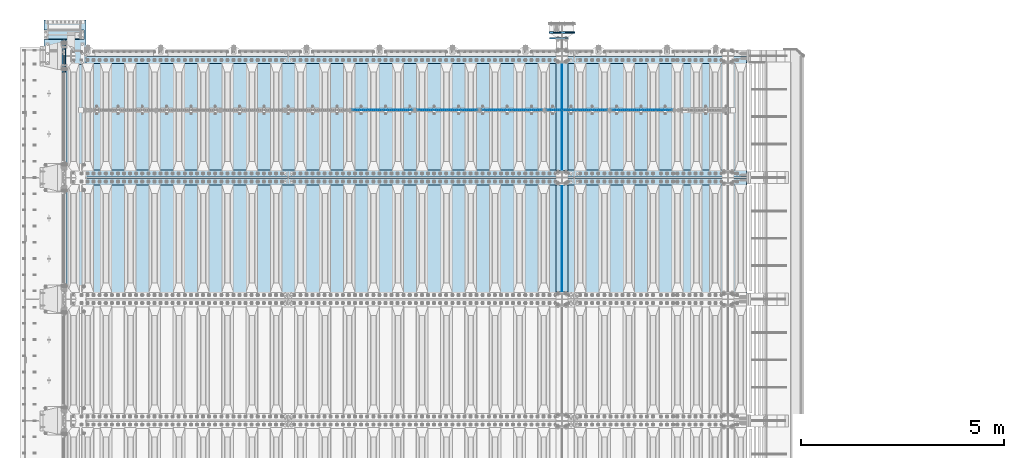
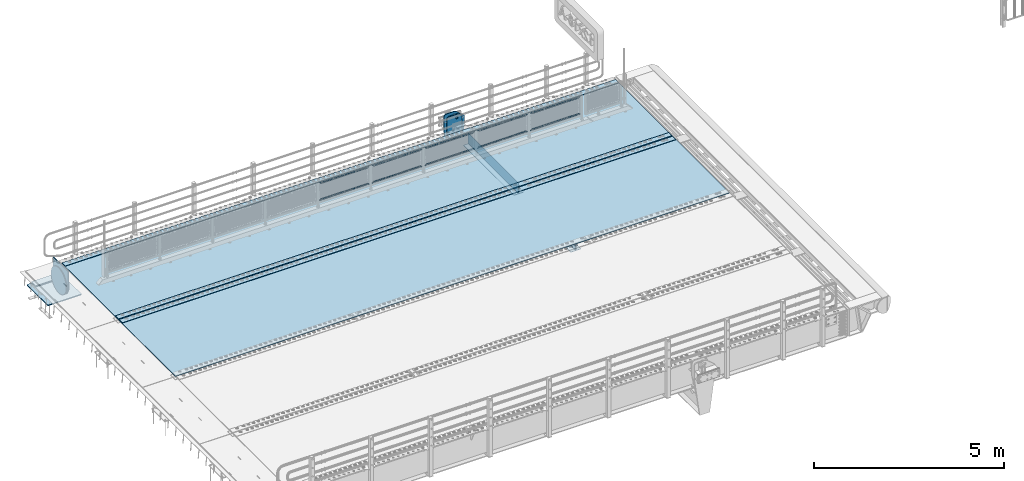
# One storey, part 200 of 257: 25 plates.
"""IFC2X3 building model written with IfcOpenShell, lengths in millimetres."""

from ifc_helpers import new_model, si_unit, frame, origin_with_axes, place, context, subcontext, project, spatial, faceted_brep, material, type_object, element, save


model = new_model("IFC2X3")

# Units and contexts
model_context = context("Model", 3, precision=1e-05, world=origin_with_axes())
body_context = subcontext(model_context, "Body", "Model", "MODEL_VIEW")
ifc_project = project(units=[si_unit("LENGTHUNIT", "METRE", prefix="MILLI"), si_unit("AREAUNIT", "SQUARE_METRE"), si_unit("VOLUMEUNIT", "CUBIC_METRE"), si_unit("MASSUNIT", "GRAM", prefix="KILO"), si_unit("TIMEUNIT", "SECOND"), si_unit("PLANEANGLEUNIT", "RADIAN"), si_unit("SOLIDANGLEUNIT", "STERADIAN"), si_unit("THERMODYNAMICTEMPERATUREUNIT", "DEGREE_CELSIUS"), si_unit("LUMINOUSINTENSITYUNIT", "LUMEN")], contexts=[model_context])

# Site, building, storey
site_placement = place(None, origin_with_axes())
site = spatial("IfcSite", under=ifc_project, at=site_placement, CompositionType="ELEMENT")
building_placement = place(site_placement, origin_with_axes())
building = spatial("IfcBuilding", under=site, at=building_placement, Name="Standard", CompositionType="ELEMENT")
storey_placement = place(building_placement, origin_with_axes())
storey = spatial("IfcBuildingStorey", under=building, at=storey_placement, Name="Undefined", CompositionType="ELEMENT", Elevation=0.0)

# Plates
ifc_material_1 = material(Name="STEEL/S355N")
plate_type_1 = type_object("IfcPlateType", PredefinedType="NOTDEFINED")
for number, where, z_axis, x_axis in (
    (1, (54550.0, 6175.0, -343.0), (0.0, 1.0, 0.0), (1.0, 0.0, 0.0)),
    (2, (54550.0, 9175.0, -343.0), (0.0, 1.0, 0.0), (1.0, 0.0, 0.0)),
):
    element("IfcPlate", number, at=place(storey_placement, frame(where, z_axis=z_axis, x_axis=x_axis)), inside=storey, type_object=plate_type_1, material=ifc_material_1, context=body_context, shape_type="Brep", body=[
        faceted_brep([(0.0, -7.0, 0.0), (0.0, -7.0, 2650.0), (0.0, 7.0, 2650.0), (0.0, 7.0, 0.0), (300.0, -7.0, 2650.0), (300.0, 7.0, 2650.0), (300.0, -7.0, 0.0), (300.0, 7.0, 0.0)], [[[0, 1, 2, 3]], [[1, 4, 5, 2]], [[4, 6, 7, 5]], [[6, 0, 3, 7]], [[5, 7, 3, 2]], [[6, 4, 1, 0]]]),
    ])
plate_type_2 = type_object("IfcPlateType", PredefinedType="NOTDEFINED")
for number, where, z_axis, x_axis in (
    (3, (54700.0, 8825.0, 0.0), (0.0, 0.0, -1.0), (0.0, -1.0, 0.0)),
    (4, (54700.0, 11825.0, 0.0), (0.0, 0.0, -1.0), (0.0, -1.0, 0.0)),
):
    element("IfcPlate", number, at=place(storey_placement, frame(where, z_axis=z_axis, x_axis=x_axis)), inside=storey, type_object=plate_type_2, material=ifc_material_1, context=body_context, shape_type="Brep", body=[
        faceted_brep([(0.0, -5.0, 0.0), (0.0, -5.0, 336.0), (0.0, 5.0, 336.0), (0.0, 5.0, 0.0), (2650.0, -5.0, 336.0), (2650.0, 5.0, 336.0), (2650.0, -5.0, 0.0), (2650.0, 5.0, 0.0)], [[[0, 1, 2, 3]], [[1, 4, 5, 2]], [[4, 6, 7, 5]], [[6, 0, 3, 7]], [[5, 7, 3, 2]], [[6, 4, 1, 0]]]),
    ])
ifc_material_2 = material(Name="Misc_Undefined")
plate_type_3 = type_object("IfcPlateType", PredefinedType="NOTDEFINED")
plate_1_placement = place(storey_placement, frame((55924.5050117304, 10670.5, 351.520303374641), z_axis=(0.0, 0.0, 1.0), x_axis=(1.0, 0.0, 0.0)))
element("IfcPlate", 5, at=plate_1_placement, inside=storey, type_object=plate_type_3, material=ifc_material_2, context=body_context, shape_type="Brep", body=[
    faceted_brep([(0.0, -1.5, -5.6843418860808e-14), (35.0002975463867, -1.5, 34.9996948242187), (35.0002975463867, 1.5, 34.9996948242187), (0.0, 1.5, -5.6843418860808e-14), (1457.99035644531, -1.5, 34.9999923706054), (1457.99035644531, 1.5, 34.9999923706054), (1492.98999023438, -1.5, -2.87985812974512e-09), (1492.98999023438, 1.5, -2.87985812974512e-09)], [[[0, 1, 2, 3]], [[1, 4, 5, 2]], [[4, 6, 7, 5]], [[6, 0, 3, 7]], [[5, 7, 3, 2]], [[6, 4, 1, 0]]]),
])
plate_2_placement = place(storey_placement, frame((57417.5000001876, 10670.5, 914.520000175701), z_axis=(-0.707103624179501, 0.0, 0.707109938179499), x_axis=(-0.707109938179488, 0.0, -0.707103624179512)))
element("IfcPlate", 6, at=plate_2_placement, inside=storey, type_object=plate_type_3, material=ifc_material_2, context=body_context, shape_type="Brep", body=[
    faceted_brep([(0.0, -1.5, -5.6843418860808e-14), (1055.71520996094, -1.5, 1055.70581054687), (1055.71520996094, 1.5, 1055.70581054687), (0.0, 1.5, -5.6843418860808e-14), (1055.70812988282, -1.5, 1006.20135498046), (1055.70812988282, 1.5, 1006.20135498046), (49.4976959228443, -1.5, 6.54836185276508e-11), (49.4976959228443, 1.5, 6.54836185276508e-11)], [[[0, 1, 2, 3]], [[1, 4, 5, 2]], [[4, 6, 7, 5]], [[6, 0, 3, 7]], [[5, 7, 3, 2]], [[6, 4, 1, 0]]]),
])
plate_3_placement = place(storey_placement, frame((54324.5050117304, 10670.5, 351.520303374641), z_axis=(0.0, 0.0, 1.0), x_axis=(1.0, 0.0, 0.0)))
element("IfcPlate", 7, at=plate_3_placement, inside=storey, type_object=plate_type_3, material=ifc_material_2, context=body_context, shape_type="Brep", body=[
    faceted_brep([(0.0, -1.5, -5.6843418860808e-14), (35.0002975463867, -1.5, 34.9996948242187), (35.0002975463867, 1.5, 34.9996948242187), (0.0, 1.5, -5.6843418860808e-14), (1457.99035644531, -1.5, 34.9999923706054), (1457.99035644531, 1.5, 34.9999923706054), (1492.98999023438, -1.5, -2.87985812974512e-09), (1492.98999023438, 1.5, -2.87985812974512e-09)], [[[0, 1, 2, 3]], [[1, 4, 5, 2]], [[4, 6, 7, 5]], [[6, 0, 3, 7]], [[5, 7, 3, 2]], [[6, 4, 1, 0]]]),
])
plate_4_placement = place(storey_placement, frame((55817.5000001876, 10670.5, 914.520000175701), z_axis=(-0.707103624179501, 0.0, 0.707109938179499), x_axis=(-0.707109938179488, 0.0, -0.707103624179512)))
element("IfcPlate", 8, at=plate_4_placement, inside=storey, type_object=plate_type_3, material=ifc_material_2, context=body_context, shape_type="Brep", body=[
    faceted_brep([(0.0, -1.5, -5.6843418860808e-14), (1055.71520996094, -1.5, 1055.70581054687), (1055.71520996094, 1.5, 1055.70581054687), (0.0, 1.5, -5.6843418860808e-14), (1055.70812988282, -1.5, 1006.20135498046), (1055.70812988282, 1.5, 1006.20135498046), (49.4976959228443, -1.5, 6.54836185276508e-11), (49.4976959228443, 1.5, 6.54836185276508e-11)], [[[0, 1, 2, 3]], [[1, 4, 5, 2]], [[4, 6, 7, 5]], [[6, 0, 3, 7]], [[5, 7, 3, 2]], [[6, 4, 1, 0]]]),
])
plate_5_placement = place(storey_placement, frame((52724.5050117304, 10670.5, 351.520303374641), z_axis=(0.0, 0.0, 1.0), x_axis=(1.0, 0.0, 0.0)))
element("IfcPlate", 9, at=plate_5_placement, inside=storey, type_object=plate_type_3, material=ifc_material_2, context=body_context, shape_type="Brep", body=[
    faceted_brep([(0.0, -1.5, -5.6843418860808e-14), (35.0002975463867, -1.5, 34.9996948242187), (35.0002975463867, 1.5, 34.9996948242187), (0.0, 1.5, -5.6843418860808e-14), (1457.99035644531, -1.5, 34.9999923706054), (1457.99035644531, 1.5, 34.9999923706054), (1492.98999023438, -1.5, -2.87985812974512e-09), (1492.98999023438, 1.5, -2.87985812974512e-09)], [[[0, 1, 2, 3]], [[1, 4, 5, 2]], [[4, 6, 7, 5]], [[6, 0, 3, 7]], [[5, 7, 3, 2]], [[6, 4, 1, 0]]]),
])
plate_6_placement = place(storey_placement, frame((54217.5000001876, 10670.5, 914.520000175701), z_axis=(-0.707103624179501, 0.0, 0.707109938179499), x_axis=(-0.707109938179488, 0.0, -0.707103624179512)))
element("IfcPlate", 10, at=plate_6_placement, inside=storey, type_object=plate_type_3, material=ifc_material_2, context=body_context, shape_type="Brep", body=[
    faceted_brep([(0.0, -1.5, -5.6843418860808e-14), (1055.71520996094, -1.5, 1055.70581054687), (1055.71520996094, 1.5, 1055.70581054687), (0.0, 1.5, -5.6843418860808e-14), (1055.70812988282, -1.5, 1006.20135498046), (1055.70812988282, 1.5, 1006.20135498046), (49.4976959228443, -1.5, 6.54836185276508e-11), (49.4976959228443, 1.5, 6.54836185276508e-11)], [[[0, 1, 2, 3]], [[1, 4, 5, 2]], [[4, 6, 7, 5]], [[6, 0, 3, 7]], [[5, 7, 3, 2]], [[6, 4, 1, 0]]]),
])
plate_7_placement = place(storey_placement, frame((51124.5050117304, 10670.5, 351.520303374641), z_axis=(0.0, 0.0, 1.0), x_axis=(1.0, 0.0, 0.0)))
element("IfcPlate", 11, at=plate_7_placement, inside=storey, type_object=plate_type_3, material=ifc_material_2, context=body_context, shape_type="Brep", body=[
    faceted_brep([(0.0, -1.5, -5.6843418860808e-14), (35.0002975463867, -1.5, 34.9996948242187), (35.0002975463867, 1.5, 34.9996948242187), (0.0, 1.5, -5.6843418860808e-14), (1457.99035644531, -1.5, 34.9999923706054), (1457.99035644531, 1.5, 34.9999923706054), (1492.98999023438, -1.5, -2.87985812974512e-09), (1492.98999023438, 1.5, -2.87985812974512e-09)], [[[0, 1, 2, 3]], [[1, 4, 5, 2]], [[4, 6, 7, 5]], [[6, 0, 3, 7]], [[5, 7, 3, 2]], [[6, 4, 1, 0]]]),
])
plate_8_placement = place(storey_placement, frame((52617.5000001876, 10670.5, 914.520000175701), z_axis=(-0.707103624179501, 0.0, 0.707109938179499), x_axis=(-0.707109938179488, 0.0, -0.707103624179512)))
element("IfcPlate", 12, at=plate_8_placement, inside=storey, type_object=plate_type_3, material=ifc_material_2, context=body_context, shape_type="Brep", body=[
    faceted_brep([(0.0, -1.5, -5.6843418860808e-14), (1055.71520996094, -1.5, 1055.70581054687), (1055.71520996094, 1.5, 1055.70581054687), (0.0, 1.5, -5.6843418860808e-14), (1055.70812988282, -1.5, 1006.20135498046), (1055.70812988282, 1.5, 1006.20135498046), (49.4976959228443, -1.5, 6.54836185276508e-11), (49.4976959228443, 1.5, 6.54836185276508e-11)], [[[0, 1, 2, 3]], [[1, 4, 5, 2]], [[4, 6, 7, 5]], [[6, 0, 3, 7]], [[5, 7, 3, 2]], [[6, 4, 1, 0]]]),
])
plate_9_placement = place(storey_placement, frame((49524.5050117304, 10670.5, 351.520303374641), z_axis=(0.0, 0.0, 1.0), x_axis=(1.0, 0.0, 0.0)))
element("IfcPlate", 13, at=plate_9_placement, inside=storey, type_object=plate_type_3, material=ifc_material_2, context=body_context, shape_type="Brep", body=[
    faceted_brep([(0.0, -1.5, -5.6843418860808e-14), (35.0002975463867, -1.5, 34.9996948242187), (35.0002975463867, 1.5, 34.9996948242187), (0.0, 1.5, -5.6843418860808e-14), (1457.99035644531, -1.5, 34.9999923706054), (1457.99035644531, 1.5, 34.9999923706054), (1492.98999023438, -1.5, -2.87985812974512e-09), (1492.98999023438, 1.5, -2.87985812974512e-09)], [[[0, 1, 2, 3]], [[1, 4, 5, 2]], [[4, 6, 7, 5]], [[6, 0, 3, 7]], [[5, 7, 3, 2]], [[6, 4, 1, 0]]]),
])
plate_10_placement = place(storey_placement, frame((51017.5000001876, 10670.5, 914.520000175701), z_axis=(-0.707103624179501, 0.0, 0.707109938179499), x_axis=(-0.707109938179488, 0.0, -0.707103624179512)))
element("IfcPlate", 14, at=plate_10_placement, inside=storey, type_object=plate_type_3, material=ifc_material_2, context=body_context, shape_type="Brep", body=[
    faceted_brep([(0.0, -1.5, -5.6843418860808e-14), (1055.71520996094, -1.5, 1055.70581054687), (1055.71520996094, 1.5, 1055.70581054687), (0.0, 1.5, -5.6843418860808e-14), (1055.70812988282, -1.5, 1006.20135498046), (1055.70812988282, 1.5, 1006.20135498046), (49.4976959228443, -1.5, 6.54836185276508e-11), (49.4976959228443, 1.5, 6.54836185276508e-11)], [[[0, 1, 2, 3]], [[1, 4, 5, 2]], [[4, 6, 7, 5]], [[6, 0, 3, 7]], [[5, 7, 3, 2]], [[6, 4, 1, 0]]]),
])
plate_type_4 = type_object("IfcPlateType", PredefinedType="NOTDEFINED")
plate_11_placement = place(storey_placement, frame((42445.0, 11600.0, -20.0), z_axis=(0.0, 1.0, 0.0), x_axis=(0.0, 0.0, -1.0)))
element("IfcPlate", 15, at=plate_11_placement, inside=storey, type_object=plate_type_4, material=ifc_material_1, context=body_context, shape_type="Brep", body=[
    faceted_brep([(855.0, -15.0, 572.96311467154), (855.0, 15.0, 572.96311467154), (849.182410261294, 15.0, 585.889268817531), (849.182410261294, -15.0, 585.889268817531), (824.193546357474, 15.0, 627.225898692485), (824.193546357474, -15.0, 627.225898692485), (794.404299268454, 15.0, 665.249063296341), (794.404299268454, -15.0, 665.249063296341), (760.249063296334, 15.0, 699.404299268464), (760.249063296334, -15.0, 699.404299268464), (722.22589869248, 15.0, 729.193546357486), (722.22589869248, -15.0, 729.193546357486), (680.889268817528, 15.0, 754.182410261309), (680.889268817528, -15.0, 754.182410261309), (636.841954817037, 15.0, 774.006497074193), (636.841954817037, -15.0, 774.006497074193), (590.726265715048, 15.0, 788.37672697045), (590.726265715048, -15.0, 788.37672697045), (543.214672102156, 15.0, 797.083549639254), (543.214672102156, -15.0, 797.083549639254), (495.0, -15.0, 800.000000000029), (495.0, 15.0, 800.0), (494.999999999412, -15.0, 0.0), (494.999999999412, 15.0, 0.0), (543.214672102129, 15.0, 2.91645036080718), (543.214672102129, -15.0, 2.91645036080718), (590.726265715023, 15.0, 11.6232730296088), (590.726265715023, -15.0, 11.6232730296088), (636.841954817014, 15.0, 25.9935029258631), (636.841954817014, -15.0, 25.9935029258631), (680.889268817507, 15.0, 45.8175897387455), (680.889268817507, -15.0, 45.8175897387455), (722.225898692462, 15.0, 70.8064536425663), (722.225898692462, -15.0, 70.8064536425663), (760.249063296318, 15.0, 100.595700731588), (760.249063296318, -15.0, 100.595700731588), (794.404299268441, 15.0, 134.750936703711), (794.404299268441, -15.0, 134.750936703711), (824.193546357463, 15.0, 172.774101307567), (824.193546357463, -15.0, 172.774101307567), (849.182410261284, 15.0, 214.110731182522), (849.182410261284, -15.0, 214.110731182522), (855.0, -15.0, 227.036885328535), (855.0, 15.0, 227.036885328535), (0.0, -15.0, 0.0), (0.0, 15.0, 0.0), (0.0, 15.0, 800.0), (0.0, -15.0, 800.0)], [[[0, 1, 2, 3]], [[3, 2, 4, 5]], [[5, 4, 6, 7]], [[7, 6, 8, 9]], [[9, 8, 10, 11]], [[11, 10, 12, 13]], [[13, 12, 14, 15]], [[15, 14, 16, 17]], [[17, 16, 18, 19]], [[20, 19, 18, 21]], [[22, 23, 24, 25]], [[25, 24, 26, 27]], [[27, 26, 28, 29]], [[29, 28, 30, 31]], [[31, 30, 32, 33]], [[33, 32, 34, 35]], [[35, 34, 36, 37]], [[37, 36, 38, 39]], [[39, 38, 40, 41]], [[42, 41, 40, 43]], [[42, 43, 1, 0]], [[44, 45, 23, 22]], [[16, 14, 12, 10, 8, 6, 4, 2, 1, 43, 40, 38, 36, 34, 32, 30, 28, 26, 24, 23, 45, 46, 21, 18]], [[44, 47, 46, 45]], [[46, 47, 20, 21]], [[47, 44, 22, 25, 27, 29, 31, 33, 35, 37, 39, 41, 42, 0, 3, 5, 7, 9, 11, 13, 15, 17, 19, 20]]]),
])
ifc_material_3 = material()
plate_type_5 = type_object("IfcPlateType", PredefinedType="NOTDEFINED")
plate_12_placement = place(storey_placement, frame((42905.0, 12645.0, -803.000000000004), z_axis=(0.0, -1.0, 0.0), x_axis=(-1.0, 0.0, 0.0)))
element("IfcPlate", 16, at=plate_12_placement, inside=storey, type_object=plate_type_5, material=ifc_material_3, context=body_context, shape_type="Brep", body=[
    faceted_brep([(0.0, 0.0, 235.0), (0.0, -15.0, 220.0), (979.0, -15.0, 220.0), (979.0, 0.0, 235.0), (0.0, 15.0, 235.0), (0.0, 15.0, 0.0), (0.0, -15.0, 0.0), (979.0, 15.0, 235.0), (979.0, -15.0, 0.0), (979.0, 15.0, 0.0)], [[[0, 1, 2, 3]], [[4, 5, 6, 1, 0]], [[7, 4, 0, 3]], [[8, 9, 7, 3, 2]], [[8, 6, 5, 9]], [[7, 9, 5, 4]], [[6, 8, 2, 1]]]),
])
plate_type_6 = type_object("IfcPlateType", PredefinedType="NOTDEFINED")
plate_13_placement = place(storey_placement, frame((41926.0, 12890.0, -1043.0), z_axis=(1.0, 0.0, 0.0), x_axis=(0.0, -1.0, 0.0)))
element("IfcPlate", 17, at=plate_13_placement, inside=storey, type_object=plate_type_6, material=ifc_material_3, context=body_context, shape_type="Brep", body=[
    faceted_brep([(0.0, -15.0, 0.0), (3.03448287013453e-05, -15.0, 1025.0), (3.03448287013453e-05, 15.0, 1025.0), (0.0, 15.0, 0.0), (1100.0, -15.0, 1025.0), (1100.0, 15.0, 1025.0), (1100.0, -15.0, -2.18278728425503e-11), (1100.0, 15.0, -2.18278728425503e-11)], [[[0, 1, 2, 3]], [[1, 4, 5, 2]], [[4, 6, 7, 5]], [[6, 0, 3, 7]], [[5, 7, 3, 2]], [[6, 4, 1, 0]]]),
])
ifc_material_4 = material(Name="STEEL/S235JR")
plate_type_7 = type_object("IfcPlateType", PredefinedType="NOTDEFINED")
for number, where, z_axis, x_axis in (
    (18, (59257.0, 8815.0, 20.0), (-1.0, 0.0, 0.0), (0.0, 1.0, 0.0)),
    (19, (59257.0, 11815.0, 20.0), (-1.0, 0.0, 0.0), (0.0, 1.0, 0.0)),
    (20, (59257.0, 9015.0, 20.0), (-1.0, 0.0, 0.0), (0.0, 1.0, 0.0)),
):
    element("IfcPlate", number, at=place(storey_placement, frame(where, z_axis=z_axis, x_axis=x_axis)), inside=storey, type_object=plate_type_7, material=ifc_material_4, context=body_context, shape_type="Brep", body=[
        faceted_brep([(0.0, -6.0, 0.0), (0.0, -6.0, 16787.0), (0.0, 6.0, 16787.0), (0.0, 6.0, 0.0), (170.0, -6.0, 16787.0), (170.0, 6.0, 16787.0), (170.0, -6.0, 0.0), (170.0, 6.0, 0.0)], [[[0, 1, 2, 3]], [[1, 4, 5, 2]], [[4, 6, 7, 5]], [[6, 0, 3, 7]], [[5, 7, 3, 2]], [[6, 4, 1, 0]]]),
    ])
plate_type_8 = type_object("IfcPlateType", PredefinedType="NOTDEFINED")
for number, where, z_axis, x_axis in (
    (21, (42460.0, 8995.0, 7.0), (1.0, 0.0, 0.0), (0.0, -1.0, 0.0)),
    (22, (42460.0, 11995.0, 7.0), (1.0, 0.0, 0.0), (0.0, -1.0, 0.0)),
):
    element("IfcPlate", number, at=place(storey_placement, frame(where, z_axis=z_axis, x_axis=x_axis)), inside=storey, type_object=plate_type_8, material=ifc_material_1, context=body_context, shape_type="Brep", body=[
        faceted_brep([(0.0, -7.0, 0.0), (-2.96859070658684e-09, -7.0, 16807.0), (-2.96859070658684e-09, 7.0, 16807.0), (0.0, 7.0, 0.0), (2990.0, -7.0, 16807.0), (2990.0, 7.0, 16807.0), (2990.0, -7.0, 0.0), (2990.0, 7.0, 0.0)], [[[0, 1, 2, 3]], [[1, 4, 5, 2]], [[4, 6, 7, 5]], [[6, 0, 3, 7]], [[5, 7, 3, 2]], [[6, 4, 1, 0]]]),
    ])
plate_type_9 = type_object("IfcPlateType", PredefinedType="NOTDEFINED")
plate_14_placement = place(storey_placement, frame((42387.5, 12400.0, -114.999999999998), z_axis=(0.0, 0.0, -1.0), x_axis=(0.0, -1.0, 0.0)))
element("IfcPlate", 23, at=plate_14_placement, inside=storey, type_object=plate_type_9, material=ifc_material_1, context=body_context, shape_type="Brep", body=[
    faceted_brep([(-1.13686837721616e-13, -12.5, 400.0), (2.91645036077841, -12.5, 448.214672102129), (2.91645036077841, 12.5, 448.214672102129), (-1.13686837721616e-13, 12.5, 400.0), (11.6232730295792, -12.5, 495.726265715023), (11.6232730295792, 12.5, 495.726265715023), (25.993502925834, -12.5, 541.841954817014), (25.993502925834, 12.5, 541.841954817014), (45.817589738716, -12.5, 585.889268817507), (45.817589738716, 12.5, 585.889268817507), (70.8064536425373, -12.5, 627.225898692462), (70.8064536425373, 12.5, 627.225898692462), (100.595700731559, -12.5, 665.249063296318), (100.595700731559, 12.5, 665.249063296318), (134.750936703682, -12.5, 699.40429926844), (134.750936703682, 12.5, 699.40429926844), (172.774101307538, -12.5, 729.193546357462), (172.774101307538, 12.5, 729.193546357462), (214.110731182492, -12.5, 754.182410261284), (214.110731182492, 12.5, 754.182410261284), (258.158045182986, -12.5, 774.006497074166), (258.158045182986, 12.5, 774.006497074166), (304.273734284977, -12.5, 788.376726970421), (304.273734284977, 12.5, 788.376726970421), (351.78532789787, -12.5, 797.083549639221), (351.78532789787, 12.5, 797.083549639221), (400.0, -12.5, 800.0), (400.0, 12.5, 800.0), (448.214672102129, -12.5, 797.083549639222), (448.214672102129, 12.5, 797.083549639222), (495.726265715023, -12.5, 788.376726970421), (495.726265715023, 12.5, 788.376726970421), (541.841954817014, -12.5, 774.006497074166), (541.841954817014, 12.5, 774.006497074166), (585.889268817507, -12.5, 754.182410261284), (585.889268817507, 12.5, 754.182410261284), (627.225898692462, -12.5, 729.193546357463), (627.225898692462, 12.5, 729.193546357463), (665.249063296318, -12.5, 699.404299268441), (665.249063296318, 12.5, 699.404299268441), (699.40429926844, -12.5, 665.249063296318), (699.40429926844, 12.5, 665.249063296318), (729.193546357463, -12.5, 627.225898692462), (729.193546357463, 12.5, 627.225898692462), (754.182410261284, -12.5, 585.889268817507), (754.182410261284, 12.5, 585.889268817507), (774.006497074166, -12.5, 541.841954817014), (774.006497074166, 12.5, 541.841954817014), (788.376726970421, -12.5, 495.726265715023), (788.376726970421, 12.5, 495.726265715023), (797.083549639222, -12.5, 448.214672102129), (797.083549639222, 12.5, 448.214672102129), (800.0, -12.5, 400.0), (800.0, 12.5, 400.0), (797.083549639222, -12.5, 351.785327897871), (797.083549639222, 12.5, 351.785327897871), (788.376726970421, -12.5, 304.273734284977), (788.376726970421, 12.5, 304.273734284977), (774.006497074166, -12.5, 258.158045182986), (774.006497074166, 12.5, 258.158045182986), (754.182410261284, -12.5, 214.110731182493), (754.182410261284, 12.5, 214.110731182493), (729.193546357463, -12.5, 172.774101307538), (729.193546357463, 12.5, 172.774101307538), (699.40429926844, -12.5, 134.750936703682), (699.40429926844, 12.5, 134.750936703682), (665.249063296318, -12.5, 100.59570073156), (665.249063296318, 12.5, 100.59570073156), (627.225898692462, -12.5, 70.8064536425375), (627.225898692462, 12.5, 70.8064536425375), (585.889268817507, -12.5, 45.817589738716), (585.889268817507, 12.5, 45.817589738716), (541.841954817014, -12.5, 25.9935029258342), (541.841954817014, 12.5, 25.9935029258342), (495.726265715023, -12.5, 11.6232730295793), (495.726265715023, 12.5, 11.6232730295793), (448.214672102129, -12.5, 2.91645036077847), (448.214672102129, 12.5, 2.91645036077847), (400.0, -12.5, -5.6843418860808e-14), (400.0, 12.5, -5.6843418860808e-14), (351.785327897871, -12.5, 2.91645036077836), (351.785327897871, 12.5, 2.91645036077836), (304.273734284977, -12.5, 11.6232730295792), (304.273734284977, 12.5, 11.6232730295792), (258.158045182986, -12.5, 25.993502925834), (258.158045182986, 12.5, 25.993502925834), (214.110731182492, -12.5, 45.817589738716), (214.110731182492, 12.5, 45.817589738716), (172.774101307538, -12.5, 70.8064536425374), (172.774101307538, 12.5, 70.8064536425374), (134.750936703682, -12.5, 100.595700731559), (134.750936703682, 12.5, 100.595700731559), (100.59570073156, -12.5, 134.750936703682), (100.59570073156, 12.5, 134.750936703682), (70.8064536425373, -12.5, 172.774101307538), (70.8064536425373, 12.5, 172.774101307538), (45.817589738716, -12.5, 214.110731182492), (45.817589738716, 12.5, 214.110731182492), (25.993502925834, -12.5, 258.158045182986), (25.993502925834, 12.5, 258.158045182986), (11.6232730295791, -12.5, 304.273734284977), (11.6232730295791, 12.5, 304.273734284977), (2.91645036077836, -12.5, 351.785327897871), (2.91645036077836, 12.5, 351.785327897871)], [[[0, 1, 2, 3]], [[1, 4, 5, 2]], [[4, 6, 7, 5]], [[6, 8, 9, 7]], [[8, 10, 11, 9]], [[10, 12, 13, 11]], [[12, 14, 15, 13]], [[14, 16, 17, 15]], [[16, 18, 19, 17]], [[18, 20, 21, 19]], [[20, 22, 23, 21]], [[22, 24, 25, 23]], [[24, 26, 27, 25]], [[26, 28, 29, 27]], [[28, 30, 31, 29]], [[30, 32, 33, 31]], [[32, 34, 35, 33]], [[34, 36, 37, 35]], [[36, 38, 39, 37]], [[38, 40, 41, 39]], [[40, 42, 43, 41]], [[42, 44, 45, 43]], [[44, 46, 47, 45]], [[46, 48, 49, 47]], [[48, 50, 51, 49]], [[50, 52, 53, 51]], [[52, 54, 55, 53]], [[54, 56, 57, 55]], [[56, 58, 59, 57]], [[58, 60, 61, 59]], [[60, 62, 63, 61]], [[62, 64, 65, 63]], [[64, 66, 67, 65]], [[66, 68, 69, 67]], [[68, 70, 71, 69]], [[70, 72, 73, 71]], [[72, 74, 75, 73]], [[74, 76, 77, 75]], [[76, 78, 79, 77]], [[78, 80, 81, 79]], [[80, 82, 83, 81]], [[82, 84, 85, 83]], [[84, 86, 87, 85]], [[86, 88, 89, 87]], [[88, 90, 91, 89]], [[90, 92, 93, 91]], [[92, 94, 95, 93]], [[94, 96, 97, 95]], [[96, 98, 99, 97]], [[98, 100, 101, 99]], [[100, 102, 103, 101]], [[102, 0, 3, 103]], [[5, 7, 9, 11, 13, 15, 17, 19, 21, 23, 25, 27, 29, 31, 33, 35, 37, 39, 41, 43, 45, 47, 49, 51, 53, 55, 57, 59, 61, 63, 65, 67, 69, 71, 73, 75, 77, 79, 81, 83, 85, 87, 89, 91, 93, 95, 97, 99, 101, 103, 3, 2]], [[102, 100, 98, 96, 94, 92, 90, 88, 86, 84, 82, 80, 78, 76, 74, 72, 70, 68, 66, 64, 62, 60, 58, 56, 54, 52, 50, 48, 46, 44, 42, 40, 38, 36, 34, 32, 30, 28, 26, 24, 22, 20, 18, 16, 14, 12, 10, 8, 6, 4, 1, 0]]]),
])
plate_type_10 = type_object("IfcPlateType", PredefinedType="NOTDEFINED")
plate_15_placement = place(storey_placement, frame((54859.9999999963, 12440.0000000045, -945.000019536852), z_axis=(-0.901283188008789, 0.0, 0.433230441004224), x_axis=(-0.433230441004227, 0.0, -0.901283188008787)))
element("IfcPlate", 24, at=plate_15_placement, inside=storey, type_object=plate_type_10, material=ifc_material_1, context=body_context, shape_type="Brep", body=[
    faceted_brep([(-929.368911797577, -14.9999999999945, 583.252555032159), (-929.368911797577, 15.0000000000055, 583.252555032159), (-937.308302015026, 15.0000000000055, 596.68950330693), (-937.308302015026, -14.9999999999945, 596.68950330693), (-939.501244651241, 15.0000000000055, 612.141897896712), (-939.501244651241, -14.9999999999945, 612.141897896712), (-935.613884068938, 15.0000000000055, 627.257251801493), (-935.613884068938, -14.9999999999945, 627.257251801493), (-926.238035677761, 15.0000000000055, 639.734389410318), (-926.238035677761, -14.9999999999945, 639.734389410318), (-912.801087402986, 15.0000000000055, 647.673779627759), (-912.801087402986, -14.9999999999945, 647.673779627759), (-897.348692813208, 15.0000000000055, 649.866722263985), (-897.348692813208, -14.9999999999945, 649.866722263985), (-882.23333890842, 15.0000000000055, 645.979361681682), (-882.23333890842, -14.9999999999945, 645.979361681682), (-869.756201299595, 15.0000000000055, 636.603513290502), (-869.756201299595, -14.9999999999945, 636.603513290502), (-861.81681108215, 15.0000000000055, 623.166565015716), (-861.81681108215, -14.9999999999945, 623.166565015716), (-859.623868445935, 15.0000000000055, 607.714170425941), (-859.623868445935, -14.9999999999945, 607.714170425941), (-863.511229028234, 15.0000000000055, 592.598816521153), (-863.511229028234, -14.9999999999945, 592.598816521153), (-872.887077419415, 15.0000000000055, 580.121678912335), (-872.887077419415, -14.9999999999945, 580.121678912335), (-886.32402569419, 15.0000000000055, 572.182288694887), (-886.32402569419, -14.9999999999945, 572.182288694887), (-901.776420283964, 15.0000000000055, 569.989346058675), (-901.776420283964, -14.9999999999945, 569.989346058675), (-916.891774188756, 15.0000000000055, 573.876706640978), (-916.891774188756, -14.9999999999945, 573.876706640978), (264.349935292787, -15.0, 42.1349931512304), (264.349935292787, 15.0, 42.1349931512304), (15.5957837248279, 15.0000000000036, 161.706590867943), (15.5957837248279, -14.9999999999964, 161.706590867943), (244.096420288082, -15.0, 2.3283064365387e-10), (244.096420288082, 15.0, 2.3283064365387e-10), (0.0, -15.0, 0.0), (0.0, 15.0, 0.0), (-976.801696777347, -15.0, 469.530822753906), (-976.801696777347, 15.0, 469.530822753906), (-1005.61094458149, -15.0, 584.572384687119), (-1005.61094458149, 15.0, 584.572384687119), (-1008.62082262311, -15.0, 603.3791105032), (-1008.62082262311, 15.0, 603.3791105032), (-1008.34150017789, -15.0, 622.423119553743), (-1008.34150017789, 15.0, 622.423119553743), (-1004.7813512013, -15.0, 641.133481415833), (-1004.7813512013, 15.0, 641.133481415833), (-998.047107283011, -15.0, 658.949268252029), (-998.047107283011, 15.0, 658.949268252029), (-903.393044122815, -15.0, 855.865689234553), (-903.393044122815, 15.0, 855.865689234553), (-891.965944990745, -15.0, 873.346279725985), (-891.965944990745, 15.0, 873.346279725985), (-876.403904176859, -15.0, 887.273681644809), (-876.403904176859, 15.0, 887.273681644809), (-857.767449567895, -15.0, 896.698765098503), (-857.767449567895, 15.0, 896.698765098503), (-837.326625373324, -15.0, 900.979225908755), (-837.326625373324, 15.0, 900.979225908755), (-816.474440668655, -15.0, 899.823357601344), (-816.474440668655, 15.0, 899.823357601344), (-796.63193808197, -15.0, 893.309930730415), (-796.63193808197, 15.0, 893.309930730415), (-427.105834960941, -15.0, 715.68542480468), (-427.105834960941, 15.0, 715.68542480468), (138.633743286129, -15.0, 288.410614013665), (138.633743286129, 15.0, 288.410614013665), (291.101898193356, -15.0, 97.7892227172852), (291.101898193356, 15.0, 97.7892227172852), (270.84838927841, -15.0, 55.6542422352868), (270.84838927841, 15.0, 55.6542422352868), (22.0942403398949, -14.9999999999964, 175.225838688071), (22.0942403398949, 15.0000000000036, 175.225838688071), (-855.850321927563, -15.0, 588.916357775823), (-852.143242469345, -15.0, 592.234043547585), (-847.175983338977, -15.0, 591.958700631352), (-843.858297567211, -15.0, 588.251621173127), (-844.133640483451, -15.0, 583.284362042767), (-847.840719941669, -15.0, 579.966676270997), (-852.807979072033, -15.0, 580.242019187237), (-856.125664843803, -15.0, 583.949098645455), (-844.133640483451, 15.0, 583.284362042767), (-847.840719941669, 15.0, 579.966676270997), (-843.858297567211, 15.0, 588.251621173127), (-847.175983338977, 15.0, 591.958700631352), (-852.143242469345, 15.0, 592.234043547585), (-855.850321927563, 15.0, 588.916357775823), (-856.125664843803, 15.0, 583.949098645455), (-852.807979072033, 15.0, 580.242019187237)], [[[0, 1, 2, 3]], [[3, 2, 4, 5]], [[5, 4, 6, 7]], [[7, 6, 8, 9]], [[9, 8, 10, 11]], [[11, 10, 12, 13]], [[13, 12, 14, 15]], [[15, 14, 16, 17]], [[17, 16, 18, 19]], [[19, 18, 20, 21]], [[21, 20, 22, 23]], [[23, 22, 24, 25]], [[25, 24, 26, 27]], [[27, 26, 28, 29]], [[29, 28, 30, 31]], [[31, 30, 1, 0]], [[32, 33, 34, 35]], [[36, 37, 33, 32]], [[36, 38, 39, 37]], [[38, 40, 41, 39]], [[40, 42, 43, 41]], [[42, 44, 45, 43]], [[44, 46, 47, 45]], [[46, 48, 49, 47]], [[48, 50, 51, 49]], [[50, 52, 53, 51]], [[52, 54, 55, 53]], [[54, 56, 57, 55]], [[56, 58, 59, 57]], [[58, 60, 61, 59]], [[60, 62, 63, 61]], [[62, 64, 65, 63]], [[64, 66, 67, 65]], [[66, 68, 69, 67]], [[68, 70, 71, 69]], [[71, 70, 72, 73]], [[74, 75, 73, 72]], [[35, 34, 75, 74]], [[72, 70, 68, 66, 64, 62, 60, 58, 56, 54, 52, 50, 48, 46, 44, 42, 40, 38, 36, 32, 35, 74], [3, 5, 7, 9, 11, 13, 15, 17, 19, 21, 23, 25, 27, 29, 31, 0], [76, 77, 78, 79, 80, 81, 82, 83]], [[80, 84, 85, 81]], [[79, 86, 84, 80]], [[78, 87, 86, 79]], [[77, 88, 87, 78]], [[76, 89, 88, 77]], [[83, 90, 89, 76]], [[82, 91, 90, 83]], [[81, 85, 91, 82]], [[37, 39, 41, 43, 45, 47, 49, 51, 53, 55, 57, 59, 61, 63, 65, 67, 69, 71, 73, 75, 34, 33], [26, 24, 22, 20, 18, 16, 14, 12, 10, 8, 6, 4, 2, 1, 30, 28], [84, 86, 87, 88, 89, 90, 91, 85]]]),
])
plate_type_11 = type_object("IfcPlateType", PredefinedType="NOTDEFINED")
plate_16_placement = place(storey_placement, frame((54850.0, 12580.0000000042, -1470.00001953686), z_axis=(0.0, 0.0, 1.0), x_axis=(-1.0, 0.0, 0.0)))
element("IfcPlate", 25, at=plate_16_placement, inside=storey, type_object=plate_type_11, material=ifc_material_1, context=body_context, shape_type="Brep", body=[
    faceted_brep([(113.044818699549, -14.9999999999982, 1615.3073372946), (113.044818699549, 15.0, 1615.3073372946), (121.715728752541, 15.0, 1628.28427124746), (121.715728752541, -14.9999999999982, 1628.28427124746), (134.692662705398, 15.0, 1636.95518130045), (134.692662705398, -14.9999999999982, 1636.95518130045), (150.0, 15.0, 1640.0), (150.0, -14.9999999999982, 1640.0), (165.307337294602, 15.0, 1636.95518130045), (165.307337294602, -14.9999999999982, 1636.95518130045), (178.284271247459, 15.0, 1628.28427124746), (178.284271247459, -14.9999999999982, 1628.28427124746), (186.955181300451, 15.0, 1615.3073372946), (186.955181300451, -14.9999999999982, 1615.3073372946), (190.0, 15.0, 1600.0), (190.0, -14.9999999999982, 1600.0), (186.955181300451, 15.0, 1584.6926627054), (186.955181300451, -14.9999999999982, 1584.6926627054), (178.284271247459, 15.0, 1571.71572875254), (178.284271247459, -14.9999999999982, 1571.71572875254), (165.307337294602, 15.0, 1563.04481869955), (165.307337294602, -14.9999999999982, 1563.04481869955), (150.0, 15.0, 1560.0), (150.0, -14.9999999999982, 1560.0), (134.692662705398, 15.0, 1563.04481869955), (134.692662705398, -14.9999999999982, 1563.04481869955), (121.715728752541, 15.0, 1571.71572875254), (121.715728752541, -14.9999999999982, 1571.71572875254), (113.044818699549, 15.0, 1584.6926627054), (113.044818699549, -14.9999999999982, 1584.6926627054), (110.0, 15.0, 1600.0), (110.0, -14.9999999999982, 1600.0), (300.0, -15.0, 0.0), (0.0, -15.0, 0.0), (0.0, 15.0, 0.0), (300.0, 15.0, 0.0), (462.5, -15.0, 1210.0), (462.5, 15.0, 1210.0), (462.5, -15.0, 1630.0), (462.5, 15.0, 1630.0), (459.774066103128, -15.0, 1650.7055236082), (459.774066103128, 15.0, 1650.7055236082), (451.782032302755, -15.0, 1670.0), (451.782032302755, 15.0, 1670.0), (439.068542494926, -15.0, 1686.56854249492), (439.068542494926, 15.0, 1686.56854249492), (422.5, -15.0, 1699.28203230276), (422.5, 15.0, 1699.28203230276), (403.205523608201, -15.0, 1707.27406610313), (403.205523608201, 15.0, 1707.27406610313), (382.5, -15.0, 1710.0), (382.5, 15.0, 1710.0), (151.788081037077, -15.0, 1710.0), (151.788081037077, 15.0, 1710.0), (132.694887325029, -15.0, 1708.33028179541), (132.694887325029, 15.0, 1708.33028179541), (114.181334578883, -15.0, 1703.37181734316), (114.181334578883, 15.0, 1703.37181734316), (96.8094667268524, -15.0, 1695.27513824985), (96.8094667268524, 15.0, 1695.27513824985), (81.1066678416755, -15.0, 1684.28604765144), (81.1066678416755, 15.0, 1684.28604765144), (-162.5, -15.0, 1480.0), (-162.5, 15.0, 1480.0), (-162.5, -15.0, 1210.0), (-162.5, 15.0, 1210.0), (150.0, -15.0, 1551.5), (154.596194077712, -15.0, 1549.59619407771), (156.5, -15.0, 1545.0), (154.596194077712, -15.0, 1540.40380592229), (150.0, -15.0, 1538.5), (145.403805922288, -15.0, 1540.40380592229), (143.5, -15.0, 1545.0), (145.403805922288, -15.0, 1549.59619407771), (150.0, 15.0, 1538.5), (145.403805922288, 15.0, 1540.40380592229), (154.596194077712, 15.0, 1540.40380592229), (156.5, 15.0, 1545.0), (154.596194077712, 15.0, 1549.59619407771), (150.0, 15.0, 1551.5), (145.403805922288, 15.0, 1549.59619407771), (143.5, 15.0, 1545.0)], [[[0, 1, 2, 3]], [[3, 2, 4, 5]], [[5, 4, 6, 7]], [[7, 6, 8, 9]], [[9, 8, 10, 11]], [[11, 10, 12, 13]], [[13, 12, 14, 15]], [[15, 14, 16, 17]], [[17, 16, 18, 19]], [[19, 18, 20, 21]], [[21, 20, 22, 23]], [[23, 22, 24, 25]], [[25, 24, 26, 27]], [[27, 26, 28, 29]], [[29, 28, 30, 31]], [[31, 30, 1, 0]], [[32, 33, 34, 35]], [[36, 32, 35, 37]], [[38, 36, 37, 39]], [[40, 38, 39, 41]], [[42, 40, 41, 43]], [[44, 42, 43, 45]], [[46, 44, 45, 47]], [[48, 46, 47, 49]], [[50, 48, 49, 51]], [[52, 50, 51, 53]], [[54, 52, 53, 55]], [[56, 54, 55, 57]], [[58, 56, 57, 59]], [[60, 58, 59, 61]], [[62, 60, 61, 63]], [[64, 62, 63, 65]], [[33, 64, 65, 34]], [[32, 36, 38, 40, 42, 44, 46, 48, 50, 52, 54, 56, 58, 60, 62, 64, 33], [3, 5, 7, 9, 11, 13, 15, 17, 19, 21, 23, 25, 27, 29, 31, 0], [66, 67, 68, 69, 70, 71, 72, 73]], [[70, 74, 75, 71]], [[69, 76, 74, 70]], [[68, 77, 76, 69]], [[67, 78, 77, 68]], [[66, 79, 78, 67]], [[73, 80, 79, 66]], [[72, 81, 80, 73]], [[71, 75, 81, 72]], [[63, 61, 59, 57, 55, 53, 51, 49, 47, 45, 43, 41, 39, 37, 35, 34, 65], [26, 24, 22, 20, 18, 16, 14, 12, 10, 8, 6, 4, 2, 1, 30, 28], [74, 76, 77, 78, 79, 80, 81, 75]]]),
])

save(model, "model.ifc")
